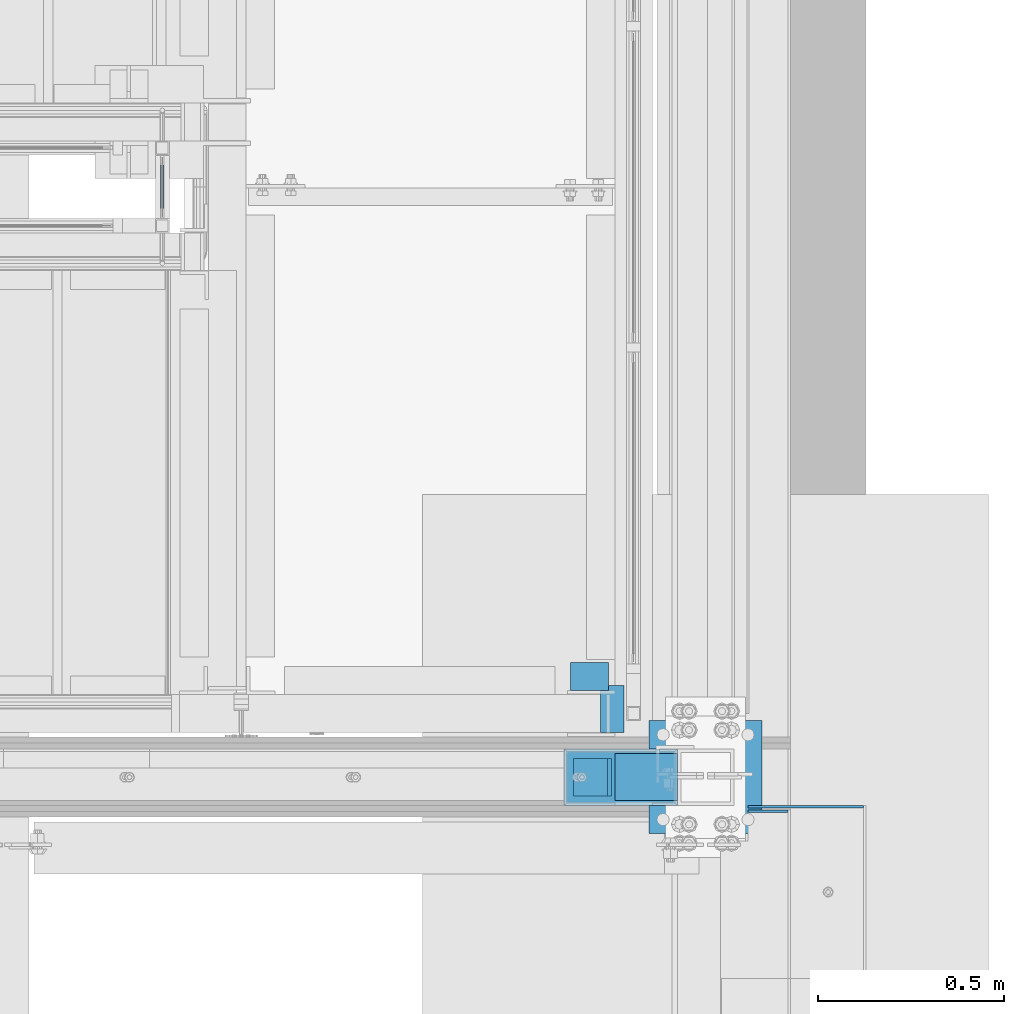
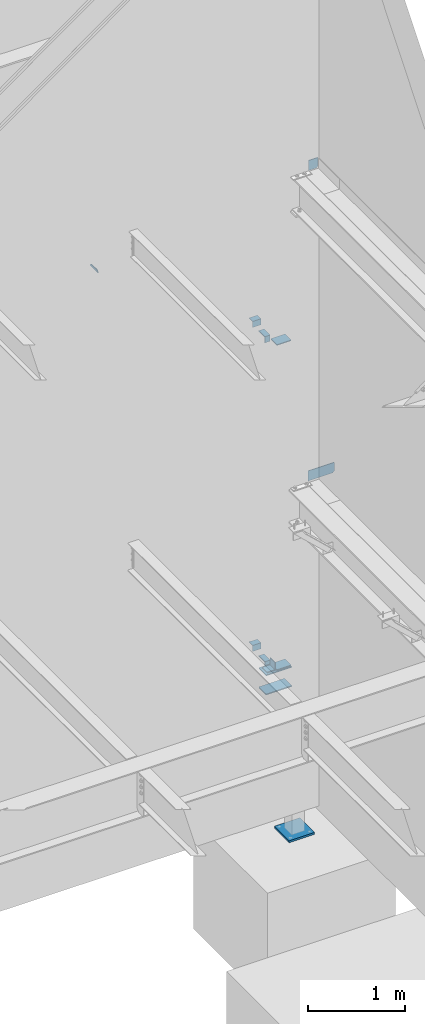
# One storey, part 920 of 1179: 17 beams, 15 elements without a shape of their own.
"""IFC2X3 building model written with IfcOpenShell, lengths in millimetres."""

from ifc_helpers import new_model, si_unit, frame, origin_with_axes, place, context, subcontext, project, spatial, faceted_brep, material, type_object, element, aggregate, save


model = new_model("IFC2X3")

# Units and contexts
model_context = context("Model", 3, precision=1e-05, world=origin_with_axes())
body_context = subcontext(model_context, "Body", "Model", "MODEL_VIEW")
ifc_project = project(units=[si_unit("LENGTHUNIT", "METRE", prefix="MILLI"), si_unit("AREAUNIT", "SQUARE_METRE"), si_unit("VOLUMEUNIT", "CUBIC_METRE"), si_unit("MASSUNIT", "GRAM", prefix="KILO"), si_unit("TIMEUNIT", "SECOND"), si_unit("PLANEANGLEUNIT", "RADIAN"), si_unit("SOLIDANGLEUNIT", "STERADIAN"), si_unit("THERMODYNAMICTEMPERATUREUNIT", "DEGREE_CELSIUS"), si_unit("LUMINOUSINTENSITYUNIT", "LUMEN")], contexts=[model_context])

# Site, building, storey
site_placement = place(None, origin_with_axes())
site = spatial("IfcSite", under=ifc_project, at=site_placement, CompositionType="ELEMENT")
building_placement = place(site_placement, origin_with_axes())
building = spatial("IfcBuilding", under=site, at=building_placement, Name="Undefined", CompositionType="ELEMENT")
storey_placement = place(building_placement, origin_with_axes())
storey = spatial("IfcBuildingStorey", under=building, at=storey_placement, Name="Undefined", CompositionType="ELEMENT", Elevation=0.0)

# Assembly, beam
assembly_1_placement = place(storey_placement, origin_with_axes())
assembly_1 = element("IfcElementAssembly", 1, at=assembly_1_placement, inside=storey, Name="GUARDRAIL", AssemblyPlace="NOTDEFINED", PredefinedType="RIGID_FRAME")
ifc_material_1 = material(Name="STEEL/BUY-OUT")
beam_type_1 = type_object("IfcBeamType", PredefinedType="NOTDEFINED")
beam_1_placement = place(assembly_1_placement, frame((22847.2998865322, 39557.3250007739, 6340.83311072469), z_axis=(0.0, -1.0, 0.0), x_axis=(0.0, 0.0, -1.0)))
beam_1 = element("IfcBeam", 2, at=beam_1_placement, type_object=beam_type_1, material=ifc_material_1, Name="U-EDGE", context=body_context, shape_type="Brep", body=[
    faceted_brep([(8.10505298431963e-08, -4.76249999999709, -77.7875001864741), (22.2250000406702, -4.76249999999709, -100.01250002037), (22.2250000406702, -1.58750000000146, -100.01250002037), (0.0, -1.58750000000146, -77.7875001054272), (0.0, 1.58750000000146, -77.7875001054272), (25.4000000406695, 1.58750000000146, -103.1875), (25.4000000406695, -7.9375, -103.1875), (8.10505298431963e-08, -7.9375, -77.7875001864741), (25.4000000406695, -7.9375, 65.0875015609054), (8.10505298431963e-08, -7.9375, 39.6875017449711), (8.10505298431963e-08, -4.76249999999709, 39.6875017449711), (22.2250000406702, -4.76249999999709, 61.9125015788668), (22.2250000406702, -1.58750000000146, 61.9125015788668), (0.0, -1.58750000000146, 39.6875016639242), (0.0, 1.58750000000146, 39.6875016639242), (25.4000000406695, 1.58750000000146, 65.0875015609054)], [[[0, 1, 2, 3, 4, 5, 6, 7]], [[7, 6, 8, 9]], [[0, 7, 9, 10]], [[1, 0, 10, 11]], [[2, 1, 11, 12]], [[3, 2, 12, 13]], [[4, 3, 13, 14]], [[5, 4, 14, 15]], [[6, 5, 15, 8]], [[14, 13, 12, 11, 10, 9, 8, 15]]]),
])
aggregate(assembly_1, [beam_1])

assembly_2_placement = place(storey_placement, origin_with_axes())
assembly_2 = element("IfcElementAssembly", 3, at=assembly_2_placement, inside=storey, Name="BEAM", AssemblyPlace="NOTDEFINED", PredefinedType="RIGID_FRAME")
ifc_material_2 = material(Name="STEEL/A36")
beam_type_2 = type_object("IfcBeamType", Name="L3X3X1/4", PredefinedType="NOTDEFINED")
beam_2_placement = place(assembly_2_placement, frame((23944.2624997714, 38257.1625000235, 6051.55), z_axis=(0.0, 0.0, -1.0), x_axis=(1.0, 0.0, 0.0)))
beam_2 = element("IfcBeam", 4, at=beam_2_placement, type_object=beam_type_2, material=ifc_material_2, Name="ANGLE", ObjectType="L3X3X1/4", context=body_context, shape_type="Brep", body=[
    faceted_brep([(0.0, 38.0999999999985, -38.0999999999999), (0.0, 38.0999999999985, 38.0999999999999), (101.600000000035, 38.0999999999985, 38.099999999994), (101.599999999962, 38.0999999999985, -38.1000000000058), (0.0, 31.75, 38.1000000000004), (101.600000000035, 31.75, 38.099999999994), (0.0, 31.75, -31.75), (101.599999999969, 31.75, -31.7500000000064), (0.0, -38.0999999999985, -31.75), (101.599999999969, -38.0999999999985, -31.7500000000064), (0.0, -38.0999999999985, -38.0999999999999), (101.599999999962, -38.0999999999985, -38.1000000000058)], [[[0, 1, 2, 3]], [[1, 4, 5, 2]], [[4, 6, 7, 5]], [[6, 8, 9, 7]], [[8, 10, 11, 9]], [[10, 0, 3, 11]], [[5, 7, 9, 11, 3, 2]], [[10, 8, 6, 4, 1, 0]]]),
])
aggregate(assembly_2, [beam_2])

assembly_3_placement = place(storey_placement, origin_with_axes())
assembly_3 = element("IfcElementAssembly", 5, at=assembly_3_placement, inside=storey, Name="BEAM", AssemblyPlace="NOTDEFINED", PredefinedType="RIGID_FRAME")
beam_3_placement = place(assembly_3_placement, frame((23944.2625001857, 38257.1625000235, 1978.025), z_axis=(0.0, 0.0, -1.0), x_axis=(1.0, 0.0, 0.0)))
beam_3 = element("IfcBeam", 6, at=beam_3_placement, type_object=beam_type_2, material=ifc_material_2, Name="ANGLE", ObjectType="L3X3X1/4", context=body_context, shape_type="Brep", body=[
    faceted_brep([(0.0, 38.0999999999985, -38.0999999999999), (0.0, 38.0999999999985, 38.0999999999999), (101.600000000035, 38.0999999999985, 38.099999999994), (101.599999999962, 38.0999999999985, -38.1000000000058), (0.0, 31.75, 38.1000000000004), (101.600000000035, 31.75, 38.099999999994), (0.0, 31.75, -31.75), (101.599999999969, 31.75, -31.7500000000064), (0.0, -38.0999999999985, -31.75), (101.599999999969, -38.0999999999985, -31.7500000000064), (0.0, -38.0999999999985, -38.0999999999999), (101.599999999962, -38.0999999999985, -38.1000000000058)], [[[0, 1, 2, 3]], [[1, 4, 5, 2]], [[4, 6, 7, 5]], [[6, 8, 9, 7]], [[8, 10, 11, 9]], [[10, 0, 3, 11]], [[5, 7, 9, 11, 3, 2]], [[10, 8, 6, 4, 1, 0]]]),
])
aggregate(assembly_3, [beam_3])

# Assembly, beams
assembly_4_placement = place(storey_placement, origin_with_axes())
assembly_4 = element("IfcElementAssembly", 7, at=assembly_4_placement, inside=storey, Name="COLUMN", AssemblyPlace="NOTDEFINED", PredefinedType="RIGID_FRAME")
beam_type_3 = type_object("IfcBeamType", Name="L4X4X3/8", PredefinedType="NOTDEFINED")
beam_4_placement = place(assembly_4_placement, frame((24002.9999999984, 37934.9, 1890.71249961063), z_axis=(-1.0, 0.0, 0.0), x_axis=(0.0, 1.0, 0.0)))
beam_4 = element("IfcBeam", 8, at=beam_4_placement, type_object=beam_type_3, material=ifc_material_2, Name="ANGLE", ObjectType="L4X4X3/8", context=body_context, shape_type="Brep", body=[
    faceted_brep([(1.90993887372315e-11, 50.8000000000002, -50.8000000000002), (1.90993887372315e-11, 50.8000000000002, 50.8000000000002), (101.599999999991, 50.7999999999993, 50.8000000000029), (101.599999999991, 50.7999999999993, -50.8000000000029), (0.0, 41.2750000000015, 50.8000000000029), (101.599999999991, 41.2750000000015, 50.8000000000029), (0.0, 41.2750000000015, -41.2750000000015), (101.599999999991, 41.2750000000015, -41.2750000000015), (0.0, -50.7999999999993, -41.2750000000015), (101.599999999991, -50.7999999999993, -41.2750000000015), (-1.81898940354586e-11, -50.7999999999997, -50.8000000000002), (101.599999999991, -50.7999999999993, -50.8000000000029)], [[[0, 1, 2, 3]], [[1, 4, 5, 2]], [[4, 6, 7, 5]], [[6, 8, 9, 7]], [[8, 10, 11, 9]], [[10, 0, 3, 11]], [[5, 7, 9, 11, 3, 2]], [[10, 8, 6, 4, 1, 0]]]),
])
beam_type_4 = type_object("IfcBeamType", PredefinedType="NOTDEFINED")
beam_5_placement = place(assembly_4_placement, frame((24231.6000004119, 37985.7, 1833.56249905573), z_axis=(0.0, 1.0, 0.0), x_axis=(-1.0, 0.0, 0.0)))
beam_5 = element("IfcBeam", 9, at=beam_5_placement, type_object=beam_type_4, material=ifc_material_2, Name="PLATE", context=body_context, shape_type="Brep", body=[
    faceted_brep([(-7.27595761418343e-12, 6.35000000000036, -76.1999999999971), (0.0, 6.35000000000036, 76.2000000000044), (304.799999999996, 6.349999999994, 76.1999999999971), (304.799999999996, 6.349999999994, -76.1999999999971), (0.0, -6.35000000000036, 76.2000000000044), (304.80000000001, -6.35000000000582, 76.1999999999971), (7.27595761418343e-12, -6.35000000000036, -76.1999999999971), (304.80000000001, -6.35000000000582, -76.1999999999971)], [[[0, 1, 2, 3]], [[1, 4, 5, 2]], [[4, 6, 7, 5]], [[6, 0, 3, 7]], [[5, 7, 3, 2]], [[6, 4, 1, 0]]]),
])
beam_6_placement = place(assembly_4_placement, frame((24231.5999999295, 37985.7, 1592.26249905573), z_axis=(0.0, -1.0, 0.0), x_axis=(-1.0, 0.0, 0.0)))
beam_6 = element("IfcBeam", 10, at=beam_6_placement, type_object=beam_type_4, material=ifc_material_2, Name="PLATE", context=body_context, shape_type="Brep", body=[
    faceted_brep([(-7.27595761418343e-12, 6.35000000000036, -76.1999999999971), (0.0, 6.35000000000036, 76.2000000000044), (304.799999999996, 6.349999999994, 76.1999999999971), (304.799999999996, 6.349999999994, -76.1999999999971), (0.0, -6.35000000000036, 76.2000000000044), (304.80000000001, -6.35000000000582, 76.1999999999971), (7.27595761418343e-12, -6.35000000000036, -76.1999999999971), (304.80000000001, -6.35000000000582, -76.1999999999971)], [[[0, 1, 2, 3]], [[1, 4, 5, 2]], [[4, 6, 7, 5]], [[6, 0, 3, 7]], [[5, 7, 3, 2]], [[6, 4, 1, 0]]]),
])
aggregate(assembly_4, [beam_4, beam_5, beam_6])

# Assembly, beam
assembly_5_placement = place(storey_placement, origin_with_axes())
assembly_5 = element("IfcElementAssembly", 11, at=assembly_5_placement, inside=storey, Name="STAIR", AssemblyPlace="NOTDEFINED", PredefinedType="RIGID_FRAME")
beam_type_5 = type_object("IfcBeamType", Name="L5X3X3/8", PredefinedType="NOTDEFINED")
beam_7_placement = place(assembly_5_placement, frame((24088.7250001143, 38169.8499999228, 5899.15000004342), z_axis=(0.0, 1.0, 0.0), x_axis=(-1.0, 0.0, 0.0)))
beam_7 = element("IfcBeam", 12, at=beam_7_placement, type_object=beam_type_5, material=ifc_material_2, Name="ANGLE", ObjectType="L5X3X3/8", context=body_context, shape_type="Brep", body=[
    faceted_brep([(0.0, 38.0999999999985, -63.5), (0.0, 38.1000000000004, 63.5), (63.5, 38.1000000000004, 63.5), (63.5, 38.1000000000004, -63.5), (0.0, 28.5749999999998, 63.5), (63.5, 28.5749999999998, 63.5), (0.0, 28.5749999999998, -53.9749999999985), (63.5, 28.5749999999998, -53.9749999999985), (0.0, -38.1000000000004, -53.9749999999985), (63.5, -38.1000000000004, -53.9749999999985), (0.0, -38.1000000000004, -63.5), (63.5, -38.1000000000004, -63.5)], [[[0, 1, 2, 3]], [[1, 4, 5, 2]], [[4, 6, 7, 5]], [[6, 8, 9, 7]], [[8, 10, 11, 9]], [[10, 0, 3, 11]], [[5, 7, 9, 11, 3, 2]], [[10, 8, 6, 4, 1, 0]]]),
])
aggregate(assembly_5, [beam_7])

assembly_6_placement = place(storey_placement, origin_with_axes())
assembly_6 = element("IfcElementAssembly", 13, at=assembly_6_placement, inside=storey, Name="STAIR", AssemblyPlace="NOTDEFINED", PredefinedType="RIGID_FRAME")
beam_8_placement = place(assembly_6_placement, frame((24088.7250005286, 38169.8499999749, 1812.92499928807), z_axis=(0.0, 1.0, 0.0), x_axis=(-1.0, 0.0, 0.0)))
beam_8 = element("IfcBeam", 14, at=beam_8_placement, type_object=beam_type_5, material=ifc_material_2, Name="ANGLE", ObjectType="L5X3X3/8", context=body_context, shape_type="Brep", body=[
    faceted_brep([(0.0, 38.0999999999985, -63.5), (0.0, 38.1000000000004, 63.5), (63.5, 38.1000000000004, 63.5), (63.5, 38.1000000000004, -63.5), (0.0, 28.5749999999998, 63.5), (63.5, 28.5749999999998, 63.5), (0.0, 28.5749999999998, -53.9749999999985), (63.5, 28.5749999999998, -53.9749999999985), (0.0, -38.1000000000004, -53.9749999999985), (63.5, -38.1000000000004, -53.9749999999985), (0.0, -38.1000000000004, -63.5), (63.5, -38.1000000000004, -63.5)], [[[0, 1, 2, 3]], [[1, 4, 5, 2]], [[4, 6, 7, 5]], [[6, 8, 9, 7]], [[8, 10, 11, 9]], [[10, 0, 3, 11]], [[5, 7, 9, 11, 3, 2]], [[10, 8, 6, 4, 1, 0]]]),
])
aggregate(assembly_6, [beam_8])

assembly_7_placement = place(storey_placement, origin_with_axes())
assembly_7 = element("IfcElementAssembly", 15, at=assembly_7_placement, inside=storey, Name="LAYER", AssemblyPlace="NOTDEFINED", PredefinedType="RIGID_FRAME")
beam_type_6 = type_object("IfcBeamType", PredefinedType="NOTDEFINED")
beam_9_placement = place(assembly_7_placement, frame((24147.4624995841, 37922.2000003367, 5928.51899960652), z_axis=(1.0, 0.0, 0.0), x_axis=(0.0, 1.0, 0.0)))
beam_9 = element("IfcBeam", 16, at=beam_9_placement, type_object=beam_type_6, material=ifc_material_2, Name="LAYER", context=body_context, shape_type="Brep", body=[
    faceted_brep([(1.52795109897852e-10, 2.38150000000041, -84.1375000000007), (-1.52795109897852e-10, 2.38150000000041, 84.1375000000007), (126.999999999847, 2.38150000000041, 84.1375000002263), (127.000000000153, 2.38150000000041, -84.1374999997752), (-1.52795109897852e-10, -2.38150000000041, 84.1375000000007), (126.999999999847, -2.38150000000041, 84.1375000002263), (1.52795109897852e-10, -2.38150000000041, -84.1375000000007), (127.000000000153, -2.38150000000041, -84.1374999997752)], [[[0, 1, 2, 3]], [[1, 4, 5, 2]], [[4, 6, 7, 5]], [[6, 0, 3, 7]], [[5, 7, 3, 2]], [[6, 4, 1, 0]]]),
])
aggregate(assembly_7, [beam_9])

assembly_8_placement = place(storey_placement, origin_with_axes())
assembly_8 = element("IfcElementAssembly", 17, at=assembly_8_placement, inside=storey, Name="LAYER", AssemblyPlace="NOTDEFINED", PredefinedType="RIGID_FRAME")
beam_10_placement = place(assembly_8_placement, frame((24147.4624999984, 37922.2000003367, 1842.29399960652), z_axis=(1.0, 0.0, 0.0), x_axis=(0.0, 1.0, 0.0)))
beam_10 = element("IfcBeam", 18, at=beam_10_placement, type_object=beam_type_6, material=ifc_material_2, Name="LAYER", context=body_context, shape_type="Brep", body=[
    faceted_brep([(1.52795109897852e-10, 2.38150000000041, -84.1375000000007), (-1.52795109897852e-10, 2.38150000000041, 84.1375000000007), (126.999999999847, 2.38150000000041, 84.1375000002263), (127.000000000153, 2.38150000000041, -84.1374999997752), (-1.52795109897852e-10, -2.38150000000041, 84.1375000000007), (126.999999999847, -2.38150000000041, 84.1375000002263), (1.52795109897852e-10, -2.38150000000041, -84.1375000000007), (127.000000000153, -2.38150000000041, -84.1374999997752)], [[[0, 1, 2, 3]], [[1, 4, 5, 2]], [[4, 6, 7, 5]], [[6, 0, 3, 7]], [[5, 7, 3, 2]], [[6, 4, 1, 0]]]),
])
aggregate(assembly_8, [beam_10])

assembly_9_placement = place(storey_placement, origin_with_axes())
assembly_9 = element("IfcElementAssembly", 19, at=assembly_9_placement, inside=storey, Name="LAYER", AssemblyPlace="NOTDEFINED", PredefinedType="RIGID_FRAME")
beam_type_7 = type_object("IfcBeamType", PredefinedType="NOTDEFINED")
beam_11_placement = place(assembly_9_placement, frame((24147.4624995857, 37922.2000003367, 5932.48749910612), z_axis=(1.0, 0.0, 0.0), x_axis=(0.0, 1.0, 0.0)))
beam_11 = element("IfcBeam", 20, at=beam_11_placement, type_object=beam_type_7, material=ifc_material_2, Name="LAYER", context=body_context, shape_type="Brep", body=[
    faceted_brep([(1.52795109897852e-10, 1.58749999999964, -84.1375000000007), (-1.52795109897852e-10, 1.58749999999964, 84.1375000000007), (126.999999999847, 1.58749999999964, 84.1375000002263), (127.000000000153, 1.58749999999964, -84.1374999997752), (-1.52795109897852e-10, -1.58749999999964, 84.1375000000007), (126.999999999847, -1.58749999999964, 84.1375000002263), (1.52795109897852e-10, -1.58749999999964, -84.1375000000007), (127.000000000153, -1.58749999999964, -84.1374999997752)], [[[0, 1, 2, 3]], [[1, 4, 5, 2]], [[4, 6, 7, 5]], [[6, 0, 3, 7]], [[5, 7, 3, 2]], [[6, 4, 1, 0]]]),
])
aggregate(assembly_9, [beam_11])

assembly_10_placement = place(storey_placement, origin_with_axes())
assembly_10 = element("IfcElementAssembly", 21, at=assembly_10_placement, inside=storey, Name="LAYER", AssemblyPlace="NOTDEFINED", PredefinedType="RIGID_FRAME")
beam_12_placement = place(assembly_10_placement, frame((24147.4624995857, 37922.2000003367, 5935.66249910612), z_axis=(1.0, 0.0, 0.0), x_axis=(0.0, 1.0, 0.0)))
beam_12 = element("IfcBeam", 22, at=beam_12_placement, type_object=beam_type_7, material=ifc_material_2, Name="LAYER", context=body_context, shape_type="Brep", body=[
    faceted_brep([(1.52795109897852e-10, 1.58749999999964, -84.1375000000007), (-1.52795109897852e-10, 1.58749999999964, 84.1375000000007), (126.999999999847, 1.58749999999964, 84.1375000002263), (127.000000000153, 1.58749999999964, -84.1374999997752), (-1.52795109897852e-10, -1.58749999999964, 84.1375000000007), (126.999999999847, -1.58749999999964, 84.1375000002263), (1.52795109897852e-10, -1.58749999999964, -84.1375000000007), (127.000000000153, -1.58749999999964, -84.1374999997752)], [[[0, 1, 2, 3]], [[1, 4, 5, 2]], [[4, 6, 7, 5]], [[6, 0, 3, 7]], [[5, 7, 3, 2]], [[6, 4, 1, 0]]]),
])
aggregate(assembly_10, [beam_12])

assembly_11_placement = place(storey_placement, origin_with_axes())
assembly_11 = element("IfcElementAssembly", 23, at=assembly_11_placement, inside=storey, Name="LAYER", AssemblyPlace="NOTDEFINED", PredefinedType="RIGID_FRAME")
beam_13_placement = place(assembly_11_placement, frame((24147.4625, 37922.2000003367, 1846.26249910611), z_axis=(1.0, 0.0, 0.0), x_axis=(0.0, 1.0, 0.0)))
beam_13 = element("IfcBeam", 24, at=beam_13_placement, type_object=beam_type_7, material=ifc_material_2, Name="LAYER", context=body_context, shape_type="Brep", body=[
    faceted_brep([(1.52795109897852e-10, 1.58749999999964, -84.1375000000007), (-1.52795109897852e-10, 1.58749999999964, 84.1375000000007), (126.999999999847, 1.58749999999964, 84.1375000002263), (127.000000000153, 1.58749999999964, -84.1374999997752), (-1.52795109897852e-10, -1.58749999999964, 84.1375000000007), (126.999999999847, -1.58749999999964, 84.1375000002263), (1.52795109897852e-10, -1.58749999999964, -84.1375000000007), (127.000000000153, -1.58749999999964, -84.1374999997752)], [[[0, 1, 2, 3]], [[1, 4, 5, 2]], [[4, 6, 7, 5]], [[6, 0, 3, 7]], [[5, 7, 3, 2]], [[6, 4, 1, 0]]]),
])
aggregate(assembly_11, [beam_13])

assembly_12_placement = place(storey_placement, origin_with_axes())
assembly_12 = element("IfcElementAssembly", 25, at=assembly_12_placement, inside=storey, Name="LAYER", AssemblyPlace="NOTDEFINED", PredefinedType="RIGID_FRAME")
beam_14_placement = place(assembly_12_placement, frame((24147.4625, 37922.2000003367, 1849.43749910611), z_axis=(1.0, 0.0, 0.0), x_axis=(0.0, 1.0, 0.0)))
beam_14 = element("IfcBeam", 26, at=beam_14_placement, type_object=beam_type_7, material=ifc_material_2, Name="LAYER", context=body_context, shape_type="Brep", body=[
    faceted_brep([(1.52795109897852e-10, 1.58749999999964, -84.1375000000007), (-1.52795109897852e-10, 1.58749999999964, 84.1375000000007), (126.999999999847, 1.58749999999964, 84.1375000002263), (127.000000000153, 1.58749999999964, -84.1374999997752), (-1.52795109897852e-10, -1.58749999999964, 84.1375000000007), (126.999999999847, -1.58749999999964, 84.1375000002263), (1.52795109897852e-10, -1.58749999999964, -84.1375000000007), (127.000000000153, -1.58749999999964, -84.1374999997752)], [[[0, 1, 2, 3]], [[1, 4, 5, 2]], [[4, 6, 7, 5]], [[6, 0, 3, 7]], [[5, 7, 3, 2]], [[6, 4, 1, 0]]]),
])
aggregate(assembly_12, [beam_14])

assembly_13_placement = place(storey_placement, origin_with_axes())
assembly_13 = element("IfcElementAssembly", 27, at=assembly_13_placement, inside=storey, Name="BEAM", AssemblyPlace="NOTDEFINED", PredefinedType="RIGID_FRAME")
beam_type_8 = type_object("IfcBeamType", PredefinedType="NOTDEFINED")
beam_15_placement = place(assembly_13_placement, frame((24422.0999938965, 37906.325, 4171.95000610352), z_axis=(0.0, 0.0, 1.0), x_axis=(1.0, 0.0, 0.0)))
beam_15 = element("IfcBeam", 28, at=beam_15_placement, type_object=beam_type_8, material=ifc_material_2, Name="PLATE", context=body_context, shape_type="Brep", body=[
    faceted_brep([(311.150006103519, -3.17500000000291, -44.4499999999998), (292.100006103519, -3.17500000000291, -63.5), (292.100006103519, 3.17500000000291, -63.5), (311.150006103519, 3.17500000000291, -44.4499999999998), (0.0, 3.17499999999927, -63.5), (0.0, 3.17499999999927, 63.5), (311.150006103519, 3.17500000000291, 63.5), (0.0, -3.17499999999927, 63.5), (311.150006103519, -3.17500000000291, 63.5), (0.0, -3.17499999999927, -63.5)], [[[0, 1, 2, 3]], [[4, 5, 6, 3, 2]], [[5, 7, 8, 6]], [[8, 7, 9, 1, 0]], [[9, 4, 2, 1]], [[6, 8, 0, 3]], [[9, 7, 5, 4]]]),
])
aggregate(assembly_13, [beam_15])

assembly_14_placement = place(storey_placement, origin_with_axes())
assembly_14 = element("IfcElementAssembly", 29, at=assembly_14_placement, inside=storey, Name="BEAM", AssemblyPlace="NOTDEFINED", PredefinedType="RIGID_FRAME")
beam_type_9 = type_object("IfcBeamType", PredefinedType="NOTDEFINED")
beam_16_placement = place(assembly_14_placement, frame((24422.1004872373, 37893.6249998753, 8083.55000610352), z_axis=(0.0, 0.0, 1.0), x_axis=(1.0, 0.0, 0.0)))
beam_16 = element("IfcBeam", 30, at=beam_16_placement, type_object=beam_type_9, material=ifc_material_2, Name="PLATE", context=body_context, shape_type="Brep", body=[
    faceted_brep([(107.949506116987, -3.17499999990105, -44.4499999999998), (88.8995061169881, -3.1749999999156, -63.5), (88.8995061169844, 3.17500000008295, -63.5), (107.949506116984, 3.1750000000975, -44.4499999999998), (0.0, 3.17499999999927, -63.5), (0.0, 3.17499999999927, 63.5), (107.949506116984, 3.1750000000975, 63.5), (0.0, -3.17499999999927, 63.5), (107.949506116987, -3.17499999990105, 63.5), (0.0, -3.17499999999927, -63.5)], [[[0, 1, 2, 3]], [[4, 5, 6, 3, 2]], [[5, 7, 8, 6]], [[8, 7, 9, 1, 0]], [[9, 4, 2, 1]], [[6, 8, 0, 3]], [[9, 7, 5, 4]]]),
])
aggregate(assembly_14, [beam_16])

assembly_15_placement = place(storey_placement, origin_with_axes())
assembly_15 = element("IfcElementAssembly", 31, at=assembly_15_placement, inside=storey, Name="COLUMN", AssemblyPlace="NOTDEFINED", PredefinedType="RIGID_FRAME")
ifc_material_3 = material(Name="STEEL/A572-GR.50")
beam_type_10 = type_object("IfcBeamType", PredefinedType="NOTDEFINED")
beam_17_placement = place(assembly_15_placement, frame((24155.4, 37985.7, -292.099999999999), z_axis=(0.0, 1.0, 0.0), x_axis=(1.0, 0.0, 0.0)))
beam_17 = element("IfcBeam", 32, at=beam_17_placement, type_object=beam_type_10, material=ifc_material_3, context=body_context, shape_type="Brep", body=[
    faceted_brep([(-7.27595761418343e-12, 12.7, -152.400000000011), (7.27595761418343e-12, 12.7, 152.400000000011), (304.800000000494, 12.7, 152.400000000071), (304.800000000479, 12.7, -152.39999999995), (7.27595761418343e-12, -12.7, 152.400000000011), (304.800000000494, -12.7, 152.400000000071), (-7.27595761418343e-12, -12.7, -152.400000000011), (304.800000000479, -12.7, -152.39999999995)], [[[0, 1, 2, 3]], [[1, 4, 5, 2]], [[4, 6, 7, 5]], [[6, 0, 3, 7]], [[5, 7, 3, 2]], [[6, 4, 1, 0]]]),
])
aggregate(assembly_15, [beam_17])

save(model, "model.ifc")
